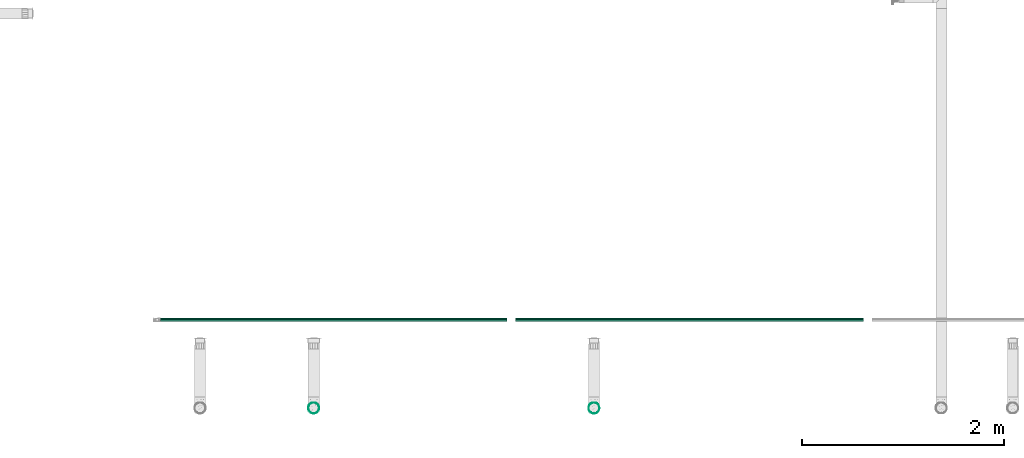
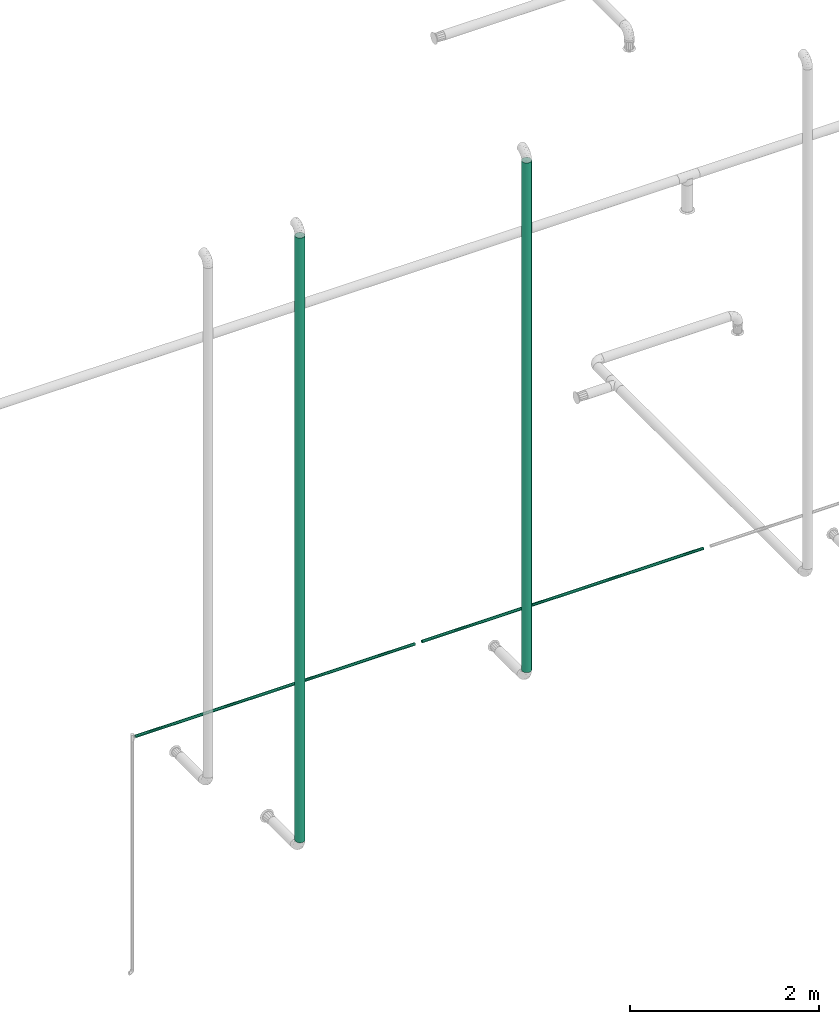
# One storey, part 12 of 123: 4 flow segments.
"""IFC2X3 building model written with IfcOpenShell, lengths in millimetres."""

import ifcopenshell
import ifcopenshell.guid

model = None  # the IFC model being written
_history = None  # IfcOwnerHistory: only IFC2X3 demands one
_inside = {}  # id of a spatial element -> (the spatial element, [elements in it])
_under = {}  # id of a project, library or spatial element -> (it, [spatial elements below it])
_declared = {}  # id of a project -> (the project, [libraries it declares])
_typed = {}  # id of a type object -> (the type object, [elements of that type])
_made_of = {}  # id of a material, layer set ... -> (it, [elements and type objects made of it])


def new_model(schema):
    """Start an empty IFC model of exactly this schema.

    Asked for "IFC4X3", IfcOpenShell would pick the latest addendum, in which some entities
    have other attributes; the version numbers below select the first issue.
    IFC2X3 requires an IfcOwnerHistory on every rooted entity: one is made here for all.
    """
    global model, _history
    if schema == "IFC4X3":
        model = ifcopenshell.file(schema_version=(4, 3, 0, 0))
    else:
        model = ifcopenshell.file(schema=schema)
    _inside.clear()
    _under.clear()
    _declared.clear()
    _typed.clear()
    _made_of.clear()
    _history = None
    if model.schema == "IFC2X3":
        org = make("IfcOrganization", Name="unknown")
        user = make(
            "IfcPersonAndOrganization",
            ThePerson=make("IfcPerson", FamilyName="unknown"),
            TheOrganization=org,
        )
        app = make(
            "IfcApplication",
            ApplicationDeveloper=org,
            Version="unknown",
            ApplicationFullName="unknown",
            ApplicationIdentifier="unknown",
        )
        _history = make(
            "IfcOwnerHistory",
            OwningUser=user,
            OwningApplication=app,
            ChangeAction="ADDED",
            CreationDate=0,
        )
    return model


def make(cls, **values):
    """One entity of the class cls with the attributes given. An attribute that is None is left unset."""
    return model.create_entity(
        cls, **{name: value for name, value in values.items() if value is not None}
    )


def entity(cls, *values):
    """Any entity or typed value of the class cls, its attributes in the order of the schema. None: left unset."""
    e = model.create_entity(cls)
    for i, value in enumerate(values):
        if value is not None:
            e[i] = value
    return e


def rooted(cls, **values):
    """An entity with a GlobalId (a new one), such as an element, a storey or a relation."""
    return make(cls, GlobalId=ifcopenshell.guid.new(), OwnerHistory=_history, **values)


def si_unit(unit_type, name, prefix=None):
    """IfcSIUnit, for example si_unit("LENGTHUNIT", "METRE", prefix="MILLI")."""
    return make("IfcSIUnit", UnitType=unit_type, Prefix=prefix, Name=name)


def converted_unit(unit_type, name, factor, base, dimensions=None, offset=None):
    """IfcConversionBasedUnit, such as the inch: factor (a typed value) times the base unit."""
    return make(
        "IfcConversionBasedUnit"
        if offset is None
        else "IfcConversionBasedUnitWithOffset",
        ConversionOffset=offset,
        Dimensions=None
        if dimensions is None
        else entity("IfcDimensionalExponents", *dimensions),
        UnitType=unit_type,
        Name=name,
        ConversionFactor=make(
            "IfcMeasureWithUnit", ValueComponent=factor, UnitComponent=base
        ),
    )


def derived_unit(unit_type, elements):
    """IfcDerivedUnit: a product of units, each with its exponent."""
    return make(
        "IfcDerivedUnit",
        Elements=[
            make("IfcDerivedUnitElement", Unit=unit, Exponent=power)
            for unit, power in elements
        ],
        UnitType=unit_type,
    )


def assignment(units):
    """IfcUnitAssignment: the units of a project."""
    return None if units is None else make("IfcUnitAssignment", Units=units)


def point(xyz):
    """IfcCartesianPoint."""
    return None if xyz is None else make("IfcCartesianPoint", Coordinates=xyz)


def direction(xyz):
    """IfcDirection."""
    return None if xyz is None else make("IfcDirection", DirectionRatios=xyz)


def frame(location, z_axis=None, x_axis=None):
    """IfcAxis2Placement3D, a coordinate frame: its origin and axes. An axis left out is left unset."""
    return make(
        "IfcAxis2Placement3D",
        Location=point(location),
        Axis=direction(z_axis),
        RefDirection=direction(x_axis),
    )


def frame_2d(location, x_axis=None):
    """IfcAxis2Placement2D, a coordinate frame in the plane: its origin and x axis."""
    return make(
        "IfcAxis2Placement2D", Location=point(location), RefDirection=direction(x_axis)
    )


def origin_with_axes():
    """The frame at (0, 0, 0) with the z axis (0, 0, 1) and the x axis (1, 0, 0) written out."""
    return frame((0.0, 0.0, 0.0), z_axis=(0.0, 0.0, 1.0), x_axis=(1.0, 0.0, 0.0))


def origin_2d_with_axis():
    """The frame at (0, 0) in the plane with the x axis (1, 0) written out."""
    return frame_2d((0.0, 0.0), x_axis=(1.0, 0.0))


def place(relative_to, where):
    """IfcLocalPlacement: puts the frame where relative to a parent placement (None: the world)."""
    return make(
        "IfcLocalPlacement", PlacementRelTo=relative_to, RelativePlacement=where
    )


def context(
    kind, dimensions, precision=None, world=None, true_north=None, identifier=None
):
    """IfcGeometricRepresentationContext, for example the 3D "Model" context."""
    return make(
        "IfcGeometricRepresentationContext",
        ContextIdentifier=identifier,
        ContextType=kind,
        CoordinateSpaceDimension=dimensions,
        Precision=precision,
        WorldCoordinateSystem=world,
        TrueNorth=true_north,
    )


def subcontext(parent, identifier, kind, view, scale=None):
    """IfcGeometricRepresentationSubContext, for example "Body" below "Model"."""
    return make(
        "IfcGeometricRepresentationSubContext",
        ContextIdentifier=identifier,
        ContextType=kind,
        ParentContext=parent,
        TargetScale=scale,
        TargetView=view,
    )


def project(units=None, contexts=None):
    """IfcProject with its units and contexts."""
    return rooted(
        "IfcProject",
        Name="project",
        RepresentationContexts=contexts,
        UnitsInContext=assignment(units),
    )


def spatial(cls, under=None, at=None, **own):
    """A site, building, storey or space (cls), placed at a placement, below another one or the project."""
    s = rooted(cls, ObjectPlacement=at, **own)
    if under is not None:
        _under.setdefault(under.id(), (under, []))[1].append(s)
    return s


def profile(cls, at=None, kind="AREA", **sizes):
    """A parametric profile (cls). Its sizes go by their IFC names, for example OverallWidth=200.0."""
    return make(cls, ProfileType=kind, Position=at, **sizes)


def hollow_circle(**sizes):
    """IfcCircleHollowProfileDef."""
    return profile("IfcCircleHollowProfileDef", **sizes)


def extrude(swept, where, along, depth):
    """IfcExtrudedAreaSolid: the profile swept, set in the frame where, extruded along a direction by depth."""
    return make(
        "IfcExtrudedAreaSolid",
        SweptArea=swept,
        Position=where,
        ExtrudedDirection=direction(along),
        Depth=depth,
    )


def shape(context_of_items, identifier, shape_type, items):
    """IfcShapeRepresentation: the items that make up one representation, for example the "Body"."""
    return make(
        "IfcShapeRepresentation",
        ContextOfItems=context_of_items,
        RepresentationIdentifier=identifier,
        RepresentationType=shape_type,
        Items=items,
    )


def source(mapping_origin, context_of_items, identifier, shape_type, items):
    """IfcRepresentationMap: a shape defined once, which mapped items show again and again."""
    return make(
        "IfcRepresentationMap",
        MappingOrigin=mapping_origin,
        MappedRepresentation=shape(context_of_items, identifier, shape_type, items),
    )


def transform(
    local_origin,
    x_axis=None,
    y_axis=None,
    z_axis=None,
    scale=None,
    scale2=None,
    scale3=None,
    uniform=True,
):
    """IfcCartesianTransformationOperator3D, or its non-uniform kind. x_axis, y_axis, z_axis: its Axis1, 2, 3."""
    if uniform:
        return make(
            "IfcCartesianTransformationOperator3D",
            Axis1=direction(x_axis),
            Axis2=direction(y_axis),
            LocalOrigin=point(local_origin),
            Scale=scale,
            Axis3=direction(z_axis),
        )
    return make(
        "IfcCartesianTransformationOperator3DnonUniform",
        Axis1=direction(x_axis),
        Axis2=direction(y_axis),
        LocalOrigin=point(local_origin),
        Scale=scale,
        Axis3=direction(z_axis),
        Scale2=scale2,
        Scale3=scale3,
    )


def mapped(mapping_source, mapping_target):
    """IfcMappedItem: shows the shape of a source again, moved by a transform."""
    return make(
        "IfcMappedItem", MappingSource=mapping_source, MappingTarget=mapping_target
    )


def material(Name=None, Category=None):
    """IfcMaterial."""
    return make("IfcMaterial", Name=Name, Category=Category)


def layer(
    of_material, thickness, ventilated=None, Name=None, Category=None, Priority=None
):
    """IfcMaterialLayer: one layer of a wall or slab, of a material (None: an air gap)."""
    return make(
        "IfcMaterialLayer",
        Material=of_material,
        LayerThickness=thickness,
        IsVentilated=ventilated,
        Name=Name,
        Category=Category,
        Priority=Priority,
    )


def layer_set(layers, Name=None):
    """IfcMaterialLayerSet."""
    return make("IfcMaterialLayerSet", MaterialLayers=layers, LayerSetName=Name)


def layer_usage(for_layer_set, set_direction, sense, offset, extent=None):
    """IfcMaterialLayerSetUsage: how a layer set lies in its element."""
    return make(
        "IfcMaterialLayerSetUsage",
        ForLayerSet=for_layer_set,
        LayerSetDirection=set_direction,
        DirectionSense=sense,
        OffsetFromReferenceLine=offset,
        ReferenceExtent=extent,
    )


def made_of(thing, what):
    """Note that an element or type object is made of a material, layer set ...; save() writes the relation."""
    if what is not None:
        _made_of.setdefault(what.id(), (what, []))[1].append(thing)
    return thing


def type_object(cls, material=None, **own):
    """A type object (cls), such as IfcWallType, which elements share."""
    return made_of(rooted(cls, **own), material)


def element(
    cls,
    number,
    at=None,
    inside=None,
    cuts=None,
    type_object=None,
    material=None,
    context=None,
    identifier="Body",
    shape_type=None,
    held_by="IfcProductDefinitionShape",
    body=None,
    shapes=None,
    **own,
):
    """One element of the class cls, such as IfcWall. Its Tag is "e" and its number.

    at: its placement. inside: the storey or other place that contains it. cuts: it is an
    opening in that element (IfcRelVoidsElement). A single representation is given by context,
    identifier, shape_type and body (its items); several are given by shapes. held_by: the class
    of the entity that holds the representations. save() writes the other relations.
    """
    e = rooted(cls, Tag="e%d" % number, ObjectPlacement=at, **own)
    if body is not None:
        shapes = [shape(context, identifier, shape_type, body)]
    if shapes is not None:
        e.Representation = make(held_by, Representations=shapes)
    if inside is not None:
        _inside.setdefault(inside.id(), (inside, []))[1].append(e)
    if cuts is not None:
        rooted(
            "IfcRelVoidsElement", RelatingBuildingElement=cuts, RelatedOpeningElement=e
        )
    if type_object is not None:
        _typed.setdefault(type_object.id(), (type_object, []))[1].append(e)
    return made_of(e, material)


def aggregate(whole, parts):
    """IfcRelAggregates: a whole, such as a stair, and the parts it consists of."""
    return rooted("IfcRelAggregates", RelatingObject=whole, RelatedObjects=parts)


def save(model, path):
    """Write the relations noted so far, then the file.

    IfcRelAggregates (storeys below a building ...), IfcRelContainedInSpatialStructure (elements
    in a storey), IfcRelDefinesByType, IfcRelAssociatesMaterial and IfcRelDeclares: one each for
    every whole, place, type object, material and project.
    """
    for whole, parts in _under.values():
        aggregate(whole, parts)
    for where, things in _inside.values():
        rooted(
            "IfcRelContainedInSpatialStructure",
            RelatedElements=things,
            RelatingStructure=where,
        )
    for kind, things in _typed.values():
        rooted("IfcRelDefinesByType", RelatedObjects=things, RelatingType=kind)
    for what, things in _made_of.values():
        rooted("IfcRelAssociatesMaterial", RelatedObjects=things, RelatingMaterial=what)
    for by, libraries in _declared.values():
        rooted("IfcRelDeclares", RelatingContext=by, RelatedDefinitions=libraries)
    model.write(path)


model = new_model("IFC2X3")

# Units and contexts
model_context = context("Model", 3, precision=1e-05, world=origin_with_axes(), true_north=direction((0.0, 1.0)))
body_context = subcontext(model_context, "Body", "Model", "MODEL_VIEW")
ifc_project = project(units=[si_unit("AREAUNIT", "SQUARE_METRE"), si_unit("VOLUMEUNIT", "CUBIC_METRE", prefix="DECI"), si_unit("TIMEUNIT", "SECOND"), si_unit("THERMODYNAMICTEMPERATUREUNIT", "DEGREE_CELSIUS"), si_unit("PRESSUREUNIT", "PASCAL"), si_unit("MASSUNIT", "GRAM", prefix="KILO"), si_unit("LENGTHUNIT", "METRE", prefix="MILLI"), si_unit("POWERUNIT", "WATT"), si_unit("ELECTRICCURRENTUNIT", "AMPERE"), si_unit("ELECTRICVOLTAGEUNIT", "VOLT"), derived_unit("VOLUMETRICFLOWRATEUNIT", [(si_unit("VOLUMEUNIT", "CUBIC_METRE", prefix="DECI"), 1), (si_unit("TIMEUNIT", "SECOND"), -1)]), derived_unit("LINEARVELOCITYUNIT", [(si_unit("LENGTHUNIT", "METRE"), 1), (si_unit("TIMEUNIT", "SECOND"), -1)]), derived_unit("MASSDENSITYUNIT", [(si_unit("MASSUNIT", "GRAM", prefix="KILO"), 1), (si_unit("VOLUMEUNIT", "CUBIC_METRE"), -1)]), converted_unit("PLANEANGLEUNIT", "DEGREE", entity("IfcRatioMeasure", 0.01745), si_unit("PLANEANGLEUNIT", "RADIAN"), dimensions=[0, 0, 0, 0, 0, 0, 0])], contexts=[model_context])

# Site, building, storey
site_placement = place(None, origin_with_axes())
site = spatial("IfcSite", under=ifc_project, at=site_placement, CompositionType="ELEMENT")
building_placement = place(site_placement, origin_with_axes())
building = spatial("IfcBuilding", under=site, at=building_placement, Name="mc-building", CompositionType="ELEMENT")
storey_placement = place(building_placement, origin_with_axes())
storey = spatial("IfcBuildingStorey", under=building, at=storey_placement, Name="1. Korrus", CompositionType="ELEMENT", Elevation=0.0)

# Flow segments
ifc_material_1 = material(Name="FZ1")
ifc_layer_1 = layer(ifc_material_1, 0.0)
ifc_layer_set_1 = layer_set([ifc_layer_1], Name="FZ1")
ifc_layer_usage_1 = layer_usage(ifc_layer_set_1, "AXIS1", "POSITIVE", 0.0)
duct_segment_type = type_object("IfcDuctSegmentType", Name="Safe", PredefinedType="RIGIDSEGMENT")
shared_shape_1 = source(origin_with_axes(), body_context, "Body", "SweptSolid", [
    extrude(hollow_circle(Radius=55.0, WallThickness=2.0, at=origin_2d_with_axis()), frame((0.0, 0.0, 0.0), z_axis=(1.0, 0.0, 0.0), x_axis=(0.0, 1.0, 0.0)), (0.0, 0.0, 1.0), 6595.0),
])
flow_segment_1_placement = place(storey_placement, frame((23048.85991, -687.64676, 2410.0), z_axis=(0.0, 1.0, 0.0), x_axis=(0.0, 0.0, 1.0)))
element("IfcFlowSegment", 1, at=flow_segment_1_placement, inside=storey, type_object=duct_segment_type, material=ifc_layer_usage_1, Name="Safe", context=body_context, shape_type="MappedRepresentation", body=[
    mapped(shared_shape_1, transform((0.0, 0.0, 0.0), scale=1.0)),
])
shared_shape_2 = source(origin_with_axes(), body_context, "Body", "SweptSolid", [
    extrude(hollow_circle(Radius=55.0, WallThickness=2.0, at=origin_2d_with_axis()), frame((0.0, 0.0, 0.0), z_axis=(1.0, 0.0, 0.0), x_axis=(0.0, 1.0, 0.0)), (0.0, 0.0, 1.0), 7825.0),
])
flow_segment_2_placement = place(storey_placement, frame((20273.93073, -687.64676, 1180.0), z_axis=(0.0, 1.0, 0.0), x_axis=(0.0, 0.0, 1.0)))
element("IfcFlowSegment", 2, at=flow_segment_2_placement, inside=storey, type_object=duct_segment_type, material=ifc_layer_usage_1, Name="Safe", context=body_context, shape_type="MappedRepresentation", body=[
    mapped(shared_shape_2, transform((0.0, 0.0, 0.0), scale=1.0)),
])
ifc_material_2 = material(Name="Steel")
ifc_layer_2 = layer(ifc_material_2, 0.0)
ifc_layer_set_2 = layer_set([ifc_layer_2], Name="Steel")
ifc_layer_usage_2 = layer_usage(ifc_layer_set_2, "AXIS1", "POSITIVE", 0.0)
pipe_segment_type = type_object("IfcPipeSegmentType", PredefinedType="RIGIDSEGMENT")
shared_shape_3 = source(origin_with_axes(), body_context, "Body", "SweptSolid", [
    extrude(hollow_circle(Radius=17.5, WallThickness=2.0, at=origin_2d_with_axis()), frame((0.0, 0.0, 0.0), z_axis=(1.0, 0.0, 0.0), x_axis=(0.0, 1.0, 0.0)), (0.0, 0.0, 1.0), 3427.1),
])
flow_segment_3_placement = place(storey_placement, frame((18757.48483, 185.02869, 2518.78858), z_axis=(0.0, 0.0, 1.0), x_axis=(1.0, 0.0, 0.0)))
element("IfcFlowSegment", 3, at=flow_segment_3_placement, inside=storey, type_object=pipe_segment_type, material=ifc_layer_usage_2, context=body_context, shape_type="MappedRepresentation", body=[
    mapped(shared_shape_3, transform((0.0, 0.0, 0.0), scale=1.0)),
])
shared_shape_4 = source(origin_with_axes(), body_context, "Body", "SweptSolid", [
    extrude(hollow_circle(Radius=17.5, WallThickness=2.0, at=origin_2d_with_axis()), frame((0.0, 0.0, 0.0), z_axis=(1.0, 0.0, 0.0), x_axis=(0.0, 1.0, 0.0)), (0.0, 0.0, 1.0), 3446.0),
])
flow_segment_4_placement = place(storey_placement, frame((22269.4117, 185.02869, 2518.78858), z_axis=(0.0, 0.0, 1.0), x_axis=(1.0, 0.0, 0.0)))
element("IfcFlowSegment", 4, at=flow_segment_4_placement, inside=storey, type_object=pipe_segment_type, material=ifc_layer_usage_2, context=body_context, shape_type="MappedRepresentation", body=[
    mapped(shared_shape_4, transform((0.0, 0.0, 0.0), scale=1.0)),
])

save(model, "model.ifc")
